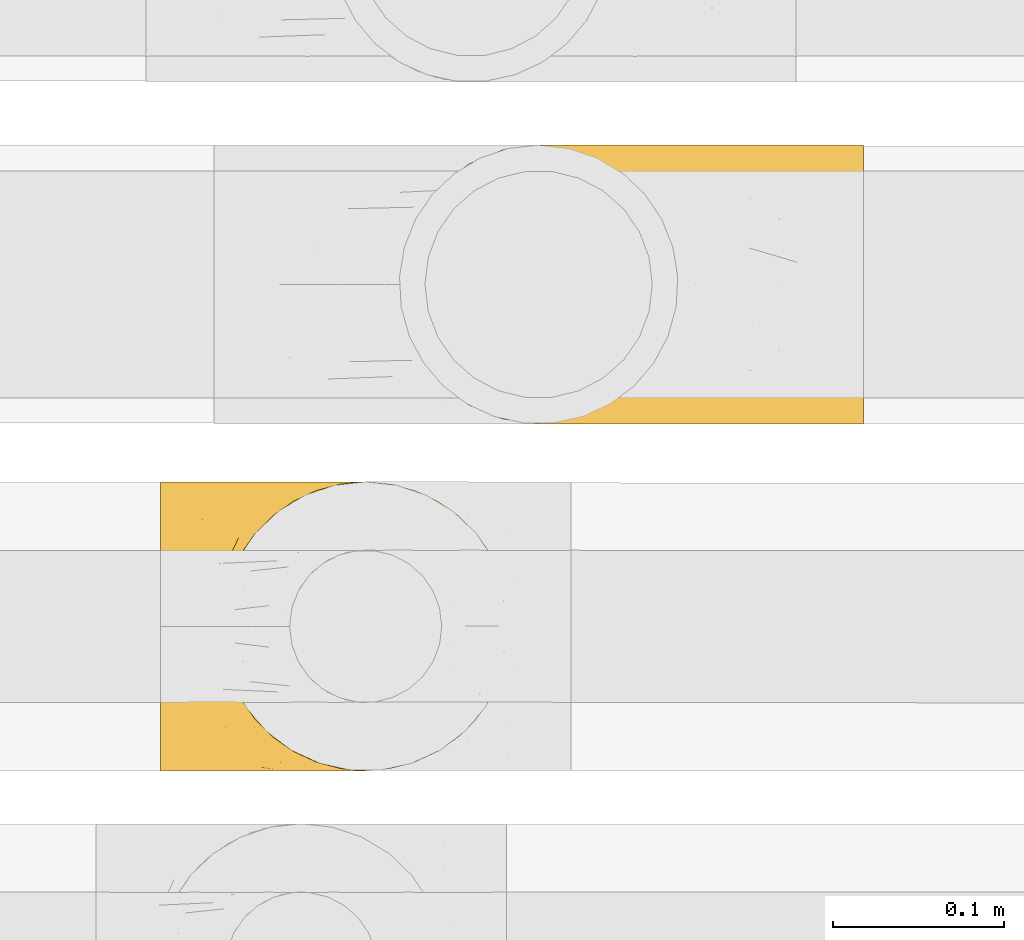
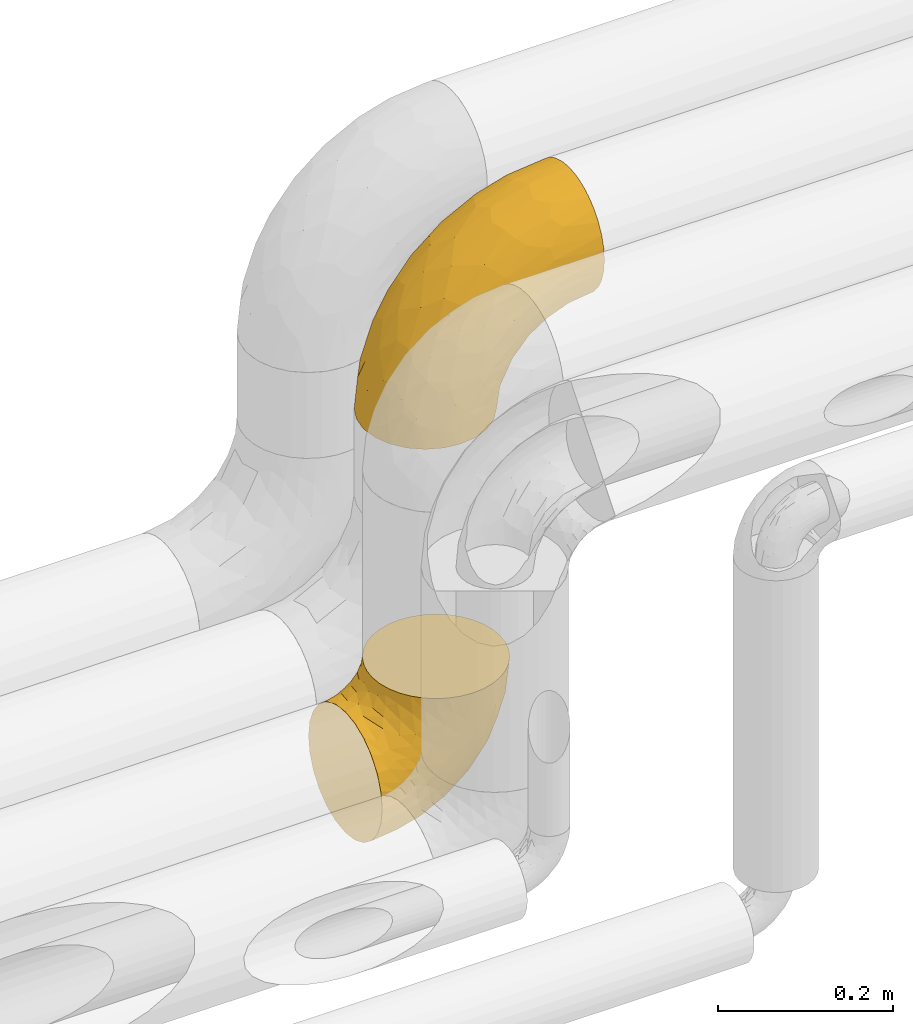
# One storey, part 15 of 93: 2 coverings.
"""IFC2X3 building model written with IfcOpenShell, lengths in millimetres."""

from ifc_helpers import new_model, entity, si_unit, converted_unit, derived_unit, direction, frame, origin, place, context, subcontext, project, spatial, faceted_brep, element, save


model = new_model("IFC2X3")

# Units and contexts
model_context = context("Model", 3, precision=0.01, world=origin(), true_north=direction((6.12303176911189e-17, 1.0)))
body_context = subcontext(model_context, "Body", "Model", "MODEL_VIEW")
ifc_project = project(units=[si_unit("LENGTHUNIT", "METRE", prefix="MILLI"), si_unit("AREAUNIT", "SQUARE_METRE"), si_unit("VOLUMEUNIT", "CUBIC_METRE"), converted_unit("PLANEANGLEUNIT", "DEGREE", entity("IfcRatioMeasure", 0.0174532925199433), si_unit("PLANEANGLEUNIT", "RADIAN"), dimensions=[0, 0, 0, 0, 0, 0, 0]), si_unit("MASSUNIT", "GRAM", prefix="KILO"), derived_unit("MASSDENSITYUNIT", [(si_unit("MASSUNIT", "GRAM", prefix="KILO"), 1), (si_unit("LENGTHUNIT", "METRE"), -3)]), derived_unit("MOMENTOFINERTIAUNIT", [(si_unit("LENGTHUNIT", "METRE"), 4)]), si_unit("TIMEUNIT", "SECOND"), si_unit("FREQUENCYUNIT", "HERTZ"), si_unit("THERMODYNAMICTEMPERATUREUNIT", "DEGREE_CELSIUS"), derived_unit("THERMALTRANSMITTANCEUNIT", [(si_unit("MASSUNIT", "GRAM", prefix="KILO"), 1), (si_unit("THERMODYNAMICTEMPERATUREUNIT", "KELVIN"), -1), (si_unit("TIMEUNIT", "SECOND"), -3)]), derived_unit("VOLUMETRICFLOWRATEUNIT", [(si_unit("LENGTHUNIT", "METRE"), 3), (si_unit("TIMEUNIT", "SECOND"), -1)]), derived_unit("MASSFLOWRATEUNIT", [(si_unit("MASSUNIT", "GRAM", prefix="KILO"), 1), (si_unit("TIMEUNIT", "SECOND"), -1)]), derived_unit("ROTATIONALFREQUENCYUNIT", [(si_unit("TIMEUNIT", "SECOND"), -1)]), si_unit("ELECTRICCURRENTUNIT", "AMPERE"), si_unit("ELECTRICVOLTAGEUNIT", "VOLT"), si_unit("POWERUNIT", "WATT"), si_unit("FORCEUNIT", "NEWTON", prefix="KILO"), si_unit("ILLUMINANCEUNIT", "LUX"), si_unit("LUMINOUSFLUXUNIT", "LUMEN"), si_unit("LUMINOUSINTENSITYUNIT", "CANDELA"), derived_unit("USERDEFINED", [(si_unit("MASSUNIT", "GRAM", prefix="KILO"), -1), (si_unit("LENGTHUNIT", "METRE"), -2), (si_unit("TIMEUNIT", "SECOND"), 3), (si_unit("LUMINOUSFLUXUNIT", "LUMEN"), 1)]), derived_unit("LINEARVELOCITYUNIT", [(si_unit("LENGTHUNIT", "METRE"), 1), (si_unit("TIMEUNIT", "SECOND"), -1)]), si_unit("PRESSUREUNIT", "PASCAL"), derived_unit("USERDEFINED", [(si_unit("LENGTHUNIT", "METRE"), -2), (si_unit("MASSUNIT", "GRAM", prefix="KILO"), 1), (si_unit("TIMEUNIT", "SECOND"), -2)]), derived_unit("LINEARFORCEUNIT", [(si_unit("MASSUNIT", "GRAM", prefix="KILO"), 1), (si_unit("LENGTHUNIT", "METRE"), 1), (si_unit("TIMEUNIT", "SECOND"), -2), (si_unit("LENGTHUNIT", "METRE"), -1)]), derived_unit("PLANARFORCEUNIT", [(si_unit("MASSUNIT", "GRAM", prefix="KILO"), 1), (si_unit("LENGTHUNIT", "METRE"), 1), (si_unit("TIMEUNIT", "SECOND"), -2), (si_unit("LENGTHUNIT", "METRE"), -2)])], contexts=[model_context])

# Site, building, storey
site_placement = place(None, origin())
site = spatial("IfcSite", under=ifc_project, at=site_placement, CompositionType="ELEMENT")
building_placement = place(site_placement, origin())
building = spatial("IfcBuilding", under=site, at=building_placement, CompositionType="ELEMENT")
storey_placement = place(building_placement, frame((0.0, 0.0, -4200.0)))
storey = spatial("IfcBuildingStorey", under=building, at=storey_placement, CompositionType="ELEMENT", Elevation=-4200.0)

# Coverings
covering_1_placement = place(storey_placement, frame((-1935.28, 14216.91, 2808.4)))
element("IfcCovering", 1, at=covering_1_placement, inside=storey, Name=":ADSK_", ObjectType=":ADSK_", PredefinedType="INSULATION", context=body_context, shape_type="Brep", body=[
    faceted_brep([(273.1, 158.39, 222.78), (273.1, 150.86, 236.87), (273.1, 140.72, 249.22), (273.1, 128.37, 259.36), (273.1, 114.28, 266.89), (273.1, 98.99, 271.53), (273.1, 83.1, 273.1), (273.1, 67.2, 271.53), (273.1, 51.91, 266.89), (273.1, 37.82, 259.36), (273.1, 25.47, 249.22), (273.1, 15.33, 236.87), (273.1, 7.8, 222.78), (273.1, 3.16, 207.49), (273.1, 1.6, 191.6), (273.1, 3.16, 175.7), (273.1, 7.8, 160.41), (273.1, 15.33, 146.32), (273.1, 25.47, 133.97), (273.1, 37.82, 123.83), (273.1, 51.91, 116.3), (273.1, 67.2, 111.66), (273.1, 83.1, 110.1), (273.1, 99.0, 111.66), (273.1, 114.28, 116.3), (273.1, 128.37, 123.83), (273.1, 140.72, 133.97), (273.1, 150.86, 146.32), (273.1, 158.39, 160.41), (273.1, 163.03, 175.7), (273.1, 164.6, 191.6), (273.1, 163.03, 207.5), (161.82, 62.0, 1.6), (153.68, 42.35, 1.6), (140.72, 25.47, 1.6), (123.85, 12.51, 1.6), (104.19, 4.37, 1.6), (83.1, 1.6, 1.6), (62.0, 4.37, 1.6), (42.35, 12.51, 1.6), (25.47, 25.47, 1.6), (12.51, 42.35, 1.6), (4.37, 62.0, 1.6), (1.6, 83.1, 1.6), (4.37, 104.19, 1.6), (12.51, 123.85, 1.6), (25.47, 140.72, 1.6), (42.35, 153.68, 1.6), (62.0, 161.82, 1.6), (83.1, 164.6, 1.6), (104.19, 161.82, 1.6), (123.85, 153.68, 1.6), (140.72, 140.72, 1.6), (153.68, 123.85, 1.6), (161.82, 104.19, 1.6), (164.6, 83.1, 1.6), (15.45, 104.67, 77.51), (6.81, 83.1, 54.56), (22.26, 83.1, 105.49), (42.42, 132.71, 109.47), (71.44, 128.57, 161.95), (65.97, 140.31, 138.06), (113.44, 127.0, 205.1), (65.75, 111.93, 168.59), (103.59, 107.33, 208.94), (63.94, 96.47, 172.96), (218.6, 153.13, 226.77), (39.77, 119.3, 122.99), (36.91, 101.32, 131.27), (138.84, 142.92, 206.95), (183.71, 142.61, 230.44), (168.19, 151.87, 210.46), (71.48, 162.56, 53.16), (101.91, 164.6, 84.03), (87.86, 164.6, 43.87), (47.35, 83.1, 152.43), (167.63, 117.97, 243.25), (212.84, 119.64, 257.44), (173.72, 131.15, 237.33), (81.12, 83.1, 193.57), (122.26, 83.1, 227.34), (56.45, 156.52, 63.71), (46.95, 144.21, 92.99), (35.05, 146.25, 42.41), (24.32, 130.43, 63.41), (230.82, 164.6, 186.83), (195.92, 162.51, 195.08), (92.81, 159.97, 122.49), (82.34, 151.26, 138.28), (122.78, 151.21, 181.92), (13.53, 117.68, 48.64), (149.02, 158.25, 185.11), (154.38, 163.04, 169.75), (212.27, 105.24, 263.05), (160.47, 100.78, 246.5), (230.92, 144.52, 241.49), (98.82, 141.87, 175.87), (218.75, 132.77, 250.34), (169.2, 83.1, 252.43), (220.13, 83.1, 267.88), (190.66, 164.6, 172.78), (154.63, 164.6, 150.14), (124.55, 164.6, 120.06), (131.16, 151.23, 32.61), (150.42, 137.69, 43.04), (110.62, 161.34, 41.06), (211.28, 141.27, 119.26), (240.6, 138.72, 127.92), (223.71, 127.05, 112.47), (203.39, 109.71, 90.5), (239.57, 83.1, 104.78), (209.32, 83.1, 89.37), (171.53, 120.43, 60.79), (166.55, 138.75, 76.89), (191.93, 129.2, 93.74), (173.04, 161.91, 138.12), (198.01, 161.43, 151.34), (187.52, 155.97, 129.05), (125.16, 162.57, 89.24), (157.77, 160.03, 116.92), (158.24, 151.82, 92.03), (160.57, 117.14, 29.57), (242.02, 109.48, 110.12), (248.61, 148.92, 141.41), (220.59, 151.93, 138.22), (137.18, 154.85, 68.2), (165.92, 98.92, 26.59), (175.12, 100.98, 52.67), (185.32, 83.1, 65.37), (169.91, 83.1, 35.12), (184.45, 145.5, 106.81), (238.32, 158.16, 155.99), (217.41, 162.97, 166.25), (245.77, 162.71, 171.98), (190.73, 98.76, 74.54), (121.56, 160.15, 62.85), (249.77, 124.12, 118.88), (171.52, 154.06, 111.86), (137.18, 11.34, 68.2), (150.42, 28.5, 43.04), (166.55, 27.44, 76.89), (158.24, 14.37, 92.03), (165.92, 67.27, 26.59), (175.12, 65.22, 52.67), (223.71, 39.14, 112.47), (211.28, 24.93, 119.26), (191.92, 36.99, 93.74), (245.77, 3.48, 171.98), (203.4, 56.48, 90.5), (131.16, 14.96, 32.61), (110.62, 4.85, 41.06), (249.77, 42.07, 118.88), (240.6, 27.47, 127.91), (171.53, 45.76, 60.79), (190.73, 67.43, 74.54), (217.41, 3.22, 166.25), (238.31, 8.03, 155.99), (87.86, 1.6, 43.87), (160.57, 49.05, 29.57), (248.61, 17.27, 141.41), (242.02, 56.71, 110.12), (111.86, 3.08, 68.35), (125.16, 3.62, 89.24), (190.66, 1.6, 172.78), (154.63, 1.6, 150.14), (198.01, 4.76, 151.34), (124.55, 1.6, 120.06), (101.91, 1.6, 84.03), (184.45, 20.69, 106.81), (157.77, 6.16, 116.92), (220.59, 14.26, 138.22), (187.52, 10.22, 129.05), (173.04, 4.28, 138.12), (230.82, 1.6, 186.83), (171.95, 12.35, 111.73), (24.32, 35.76, 63.41), (183.71, 23.58, 230.44), (173.75, 35.03, 237.34), (133.19, 34.03, 214.88), (229.24, 46.35, 260.65), (79.61, 3.68, 78.77), (104.94, 3.15, 120.31), (89.58, 7.94, 125.68), (98.82, 24.32, 175.87), (84.08, 41.48, 180.24), (152.2, 6.22, 181.88), (198.75, 2.91, 192.21), (62.55, 57.48, 166.39), (58.85, 10.43, 76.36), (40.65, 33.0, 104.7), (46.95, 21.98, 92.99), (63.87, 28.1, 138.7), (22.06, 47.91, 81.73), (230.92, 21.67, 241.49), (103.59, 58.86, 208.94), (207.65, 13.93, 225.32), (39.77, 46.89, 122.99), (34.68, 62.93, 126.09), (35.05, 19.94, 42.41), (15.45, 61.52, 77.51), (150.41, 15.08, 201.91), (210.73, 6.68, 210.82), (160.46, 65.41, 246.49), (79.42, 16.65, 138.52), (115.1, 11.53, 167.35), (212.26, 60.95, 263.05), (218.75, 33.42, 250.34), (167.63, 48.22, 243.25)], [[[0, 1, 2, 3, 4, 5, 6, 7, 8, 9, 10, 11, 12, 13, 14, 15, 16, 17, 18, 19, 20, 21, 22, 23, 24, 25, 26, 27, 28, 29, 30, 31]], [[32, 33, 34, 35, 36, 37, 38, 39, 40, 41, 42, 43, 44, 45, 46, 47, 48, 49, 50, 51, 52, 53, 54, 55]], [[56, 57, 58]], [[57, 44, 43]], [[59, 60, 61]], [[62, 63, 64]], [[63, 65, 64]], [[1, 0, 66]], [[67, 68, 63]], [[69, 70, 71]], [[72, 73, 74]], [[75, 68, 58]], [[76, 77, 78]], [[64, 79, 80]], [[81, 48, 47]], [[82, 83, 84]], [[31, 85, 86]], [[71, 70, 66]], [[47, 83, 81]], [[87, 88, 89]], [[69, 62, 78]], [[49, 48, 72]], [[90, 44, 56]], [[48, 81, 72]], [[87, 91, 92]], [[93, 76, 94]], [[70, 95, 66]], [[88, 96, 89]], [[45, 84, 46]], [[2, 95, 97]], [[4, 93, 5]], [[98, 99, 93]], [[59, 84, 67]], [[3, 97, 77]], [[71, 86, 91]], [[4, 3, 77]], [[90, 84, 45]], [[99, 6, 5]], [[83, 47, 46]], [[95, 2, 1]], [[94, 80, 98]], [[100, 101, 92]], [[66, 31, 86]], [[60, 63, 62]], [[85, 31, 30]], [[102, 87, 92]], [[93, 77, 76]], [[91, 86, 92]], [[44, 57, 56]], [[86, 85, 100]], [[78, 97, 70]], [[87, 102, 73]], [[2, 97, 3]], [[67, 84, 90]], [[31, 66, 0]], [[93, 94, 98]], [[88, 81, 82]], [[99, 5, 93]], [[87, 73, 72]], [[66, 95, 1]], [[97, 95, 70]], [[86, 71, 66]], [[69, 89, 96]], [[89, 71, 91]], [[69, 96, 62]], [[60, 62, 96]], [[76, 62, 64]], [[71, 89, 69]], [[87, 89, 91]], [[81, 88, 87]], [[61, 88, 82]], [[61, 60, 96]], [[60, 67, 63]], [[68, 67, 56]], [[79, 65, 75]], [[58, 68, 56]], [[65, 68, 75]], [[64, 65, 79]], [[68, 65, 63]], [[76, 64, 94]], [[80, 94, 64]], [[100, 92, 86]], [[92, 101, 102]], [[88, 61, 96]], [[59, 61, 82]], [[84, 59, 82]], [[60, 59, 67]], [[87, 72, 81]], [[49, 72, 74]], [[84, 83, 46]], [[81, 83, 82]], [[69, 78, 70]], [[62, 76, 78]], [[4, 77, 93]], [[78, 77, 97]], [[44, 90, 45]], [[67, 90, 56]], [[103, 104, 52]], [[50, 49, 74]], [[50, 74, 105]], [[106, 107, 108]], [[109, 110, 111]], [[112, 113, 114]], [[104, 113, 112]], [[73, 105, 74]], [[115, 116, 117]], [[118, 119, 120]], [[104, 53, 52]], [[51, 103, 52]], [[53, 121, 54]], [[24, 23, 122]], [[123, 107, 124]], [[122, 109, 108]], [[125, 120, 113]], [[55, 54, 126]], [[102, 118, 73]], [[127, 126, 121]], [[128, 129, 127]], [[105, 51, 50]], [[102, 101, 119]], [[120, 130, 113]], [[26, 123, 27]], [[27, 131, 28]], [[132, 85, 133]], [[85, 29, 133]], [[134, 111, 128]], [[28, 133, 29]], [[30, 29, 85]], [[116, 131, 124]], [[135, 73, 118]], [[27, 123, 131]], [[110, 23, 22]], [[136, 122, 108]], [[24, 136, 25]], [[114, 108, 109]], [[119, 115, 117]], [[136, 107, 25]], [[128, 127, 134]], [[122, 110, 109]], [[104, 112, 121]], [[107, 106, 124]], [[107, 26, 25]], [[23, 110, 122]], [[101, 100, 116]], [[131, 132, 133]], [[105, 135, 103]], [[116, 124, 117]], [[122, 136, 24]], [[107, 136, 108]], [[28, 131, 133]], [[131, 116, 132]], [[126, 127, 129]], [[134, 112, 109]], [[107, 123, 26]], [[131, 123, 124]], [[104, 121, 53]], [[127, 121, 112]], [[105, 103, 51]], [[104, 103, 125]], [[116, 100, 132]], [[85, 132, 100]], [[106, 117, 124]], [[137, 130, 120]], [[114, 106, 108]], [[106, 130, 117]], [[119, 118, 102]], [[135, 118, 125]], [[125, 113, 104]], [[114, 113, 130]], [[114, 130, 106]], [[112, 114, 109]], [[118, 120, 125]], [[117, 137, 119]], [[55, 126, 129]], [[121, 126, 54]], [[112, 134, 127]], [[111, 134, 109]], [[119, 101, 115]], [[101, 116, 115]], [[103, 135, 125]], [[73, 135, 105]], [[130, 137, 117]], [[120, 119, 137]], [[138, 139, 140]], [[140, 141, 138]], [[55, 129, 142]], [[143, 142, 129]], [[144, 145, 146]], [[147, 16, 15]], [[110, 148, 111]], [[128, 143, 129]], [[149, 150, 35]], [[151, 152, 144]], [[153, 143, 154]], [[147, 155, 156]], [[35, 150, 36]], [[37, 36, 157]], [[35, 34, 149]], [[139, 33, 158]], [[159, 152, 18]], [[150, 157, 36]], [[140, 139, 153]], [[139, 34, 33]], [[110, 21, 160]], [[150, 161, 157]], [[20, 19, 151]], [[161, 138, 162]], [[110, 22, 21]], [[163, 164, 165]], [[166, 167, 162]], [[151, 160, 20]], [[140, 146, 168]], [[111, 148, 154]], [[164, 166, 169]], [[18, 152, 19]], [[170, 156, 165]], [[17, 159, 18]], [[158, 33, 32]], [[171, 165, 172]], [[155, 165, 156]], [[148, 110, 160]], [[170, 159, 156]], [[160, 144, 148]], [[15, 14, 173]], [[170, 171, 145]], [[149, 139, 138]], [[15, 173, 147]], [[144, 152, 145]], [[156, 17, 16]], [[165, 171, 170]], [[20, 160, 21]], [[171, 172, 169]], [[169, 166, 162]], [[152, 151, 19]], [[160, 151, 144]], [[155, 173, 163]], [[156, 16, 147]], [[154, 143, 128]], [[143, 153, 158]], [[156, 159, 17]], [[152, 159, 170]], [[158, 32, 142]], [[139, 158, 153]], [[139, 149, 34]], [[150, 149, 138]], [[173, 155, 147]], [[163, 165, 155]], [[174, 169, 141]], [[145, 171, 168]], [[170, 145, 152]], [[146, 145, 168]], [[161, 162, 167]], [[162, 138, 141]], [[146, 153, 148]], [[140, 168, 141]], [[153, 146, 140]], [[144, 146, 148]], [[174, 141, 168]], [[162, 141, 169]], [[158, 142, 143]], [[55, 142, 32]], [[111, 154, 128]], [[153, 154, 148]], [[165, 164, 172]], [[164, 169, 172]], [[157, 161, 167]], [[138, 161, 150]], [[168, 171, 174]], [[169, 174, 171]], [[41, 40, 175]], [[176, 177, 178]], [[9, 8, 179]], [[180, 181, 182]], [[157, 180, 37]], [[183, 178, 184]], [[164, 185, 181]], [[13, 186, 173]], [[187, 79, 75]], [[167, 166, 181]], [[186, 163, 173]], [[182, 188, 180]], [[57, 43, 42]], [[189, 190, 191]], [[164, 186, 185]], [[192, 41, 175]], [[193, 11, 10]], [[178, 194, 184]], [[12, 11, 195]], [[196, 187, 197]], [[40, 198, 175]], [[198, 40, 39]], [[58, 199, 197]], [[200, 185, 201]], [[163, 186, 164]], [[201, 185, 186]], [[202, 80, 194]], [[190, 203, 191]], [[201, 186, 13]], [[204, 185, 200]], [[201, 13, 12]], [[41, 199, 42]], [[195, 200, 201]], [[98, 205, 99]], [[57, 42, 199]], [[13, 173, 14]], [[58, 57, 199]], [[193, 206, 176]], [[80, 79, 194]], [[207, 205, 202]], [[196, 184, 187]], [[202, 205, 98]], [[205, 179, 8]], [[9, 206, 10]], [[207, 206, 179]], [[182, 203, 188]], [[6, 99, 7]], [[188, 38, 180]], [[203, 182, 204]], [[7, 205, 8]], [[37, 180, 38]], [[167, 180, 157]], [[7, 99, 205]], [[182, 181, 185]], [[11, 193, 195]], [[196, 191, 184]], [[175, 189, 192]], [[198, 188, 190]], [[38, 188, 39]], [[206, 193, 10]], [[195, 193, 176]], [[195, 176, 200]], [[12, 195, 201]], [[178, 200, 176]], [[185, 204, 182]], [[200, 183, 204]], [[203, 204, 183]], [[191, 203, 183]], [[188, 203, 190]], [[184, 191, 183]], [[190, 189, 175]], [[200, 178, 183]], [[184, 194, 187]], [[177, 176, 206]], [[194, 178, 207]], [[79, 187, 194]], [[197, 199, 192]], [[187, 75, 197]], [[58, 197, 75]], [[191, 196, 189]], [[192, 189, 196]], [[80, 202, 98]], [[194, 207, 202]], [[167, 181, 180]], [[181, 166, 164]], [[188, 198, 39]], [[175, 198, 190]], [[207, 179, 205]], [[9, 179, 206]], [[197, 192, 196]], [[41, 192, 199]], [[206, 207, 177]], [[207, 178, 177]]]),
])
covering_2_placement = place(storey_placement, frame((-2074.95, 14013.91, 2414.21)))
element("IfcCovering", 2, at=covering_2_placement, inside=storey, Name=":ADSK_", ObjectType=":ADSK_", PredefinedType="INSULATION", context=body_context, shape_type="Brep", body=[
    faceted_brep([(150.5, 6.69, 206.1), (163.85, 12.92, 206.1), (175.91, 21.37, 206.1), (186.33, 31.78, 206.1), (194.77, 43.85, 206.1), (201.0, 57.19, 206.1), (204.81, 71.42, 206.1), (206.1, 86.1, 206.1), (204.81, 100.77, 206.1), (201.0, 115.0, 206.1), (194.77, 128.35, 206.1), (186.32, 140.41, 206.1), (175.91, 150.83, 206.1), (163.84, 159.27, 206.1), (150.5, 165.5, 206.1), (136.27, 169.31, 206.1), (121.6, 170.6, 206.1), (106.92, 169.31, 206.1), (92.69, 165.5, 206.1), (79.34, 159.27, 206.1), (67.28, 150.82, 206.1), (56.86, 140.41, 206.1), (48.42, 128.34, 206.1), (42.19, 115.0, 206.1), (38.38, 100.77, 206.1), (37.1, 86.1, 206.1), (38.38, 71.42, 206.1), (42.19, 57.19, 206.1), (48.42, 43.84, 206.1), (56.87, 31.78, 206.1), (67.28, 21.36, 206.1), (79.35, 12.92, 206.1), (92.69, 6.69, 206.1), (99.81, 4.79, 206.1), (106.92, 2.88, 206.1), (121.6, 1.6, 206.1), (136.27, 2.88, 206.1), (1.6, 86.1, 170.6), (1.6, 107.97, 167.72), (1.6, 128.35, 159.27), (1.6, 145.85, 145.85), (1.6, 159.27, 128.35), (1.6, 167.72, 107.97), (1.6, 168.82, 99.56), (1.6, 170.6, 86.1), (1.6, 167.72, 64.23), (1.6, 159.27, 43.85), (1.6, 145.85, 26.34), (1.6, 128.35, 12.92), (1.6, 107.97, 4.47), (1.6, 86.1, 1.6), (1.6, 64.23, 4.47), (1.6, 43.85, 12.92), (1.6, 26.34, 26.34), (1.6, 12.92, 43.85), (1.6, 4.47, 64.23), (1.6, 1.6, 86.1), (1.6, 3.37, 99.56), (1.6, 4.47, 107.97), (1.6, 8.7, 118.16), (1.6, 12.92, 128.35), (1.6, 26.34, 145.85), (1.6, 43.85, 159.27), (1.6, 64.23, 167.72), (47.1, 86.1, 6.72), (90.32, 86.1, 21.85), (76.74, 70.39, 17.49), (45.07, 70.66, 7.72), (54.43, 56.88, 13.94), (130.85, 28.12, 78.7), (102.9, 18.64, 68.47), (101.57, 31.21, 51.33), (129.1, 86.1, 46.21), (109.1, 70.41, 33.86), (42.18, 10.43, 53.79), (157.11, 29.48, 110.17), (165.26, 21.45, 145.81), (145.37, 16.68, 118.82), (180.34, 29.1, 169.84), (144.69, 67.25, 63.0), (161.48, 86.1, 78.59), (172.76, 63.85, 99.74), (29.38, 21.08, 34.35), (42.46, 37.65, 21.32), (194.48, 53.11, 162.31), (193.55, 69.85, 140.29), (201.3, 66.89, 173.87), (46.37, 4.01, 73.41), (101.41, 4.29, 106.28), (98.68, 1.6, 135.56), (85.4, 1.6, 122.29), (72.13, 1.6, 109.01), (137.0, 8.08, 136.01), (119.7, 12.22, 96.64), (119.97, 3.07, 139.72), (115.72, 1.6, 169.01), (107.2, 1.6, 152.29), (76.04, 4.22, 86.47), (55.4, 1.6, 100.49), (38.68, 1.6, 91.97), (185.84, 86.1, 117.37), (177.95, 43.5, 127.74), (157.62, 11.81, 169.45), (65.3, 23.97, 40.66), (82.09, 9.27, 73.41), (149.99, 46.38, 80.23), (200.97, 86.1, 160.59), (136.93, 4.15, 167.92), (119.25, 1.6, 191.28), (117.49, 1.6, 180.15), (104.96, 52.19, 37.92), (75.57, 36.38, 32.9), (27.54, 1.6, 90.21), (16.41, 1.6, 88.44), (48.91, 15.12, 149.02), (55.45, 17.96, 161.35), (39.69, 27.16, 160.46), (35.54, 7.89, 124.9), (48.76, 3.04, 112.91), (52.0, 5.06, 124.31), (27.71, 4.56, 111.82), (19.57, 3.21, 104.11), (26.99, 15.37, 136.85), (16.3, 12.85, 129.63), (56.69, 27.24, 183.96), (44.9, 34.03, 174.77), (14.18, 23.54, 144.17), (32.34, 86.1, 188.35), (26.88, 67.27, 178.24), (35.03, 70.89, 190.53), (12.19, 48.67, 163.14), (46.38, 43.58, 191.92), (14.56, 68.19, 170.99), (31.42, 50.33, 174.51), (25.84, 42.35, 165.01), (80.65, 11.32, 190.2), (67.99, 19.09, 189.17), (86.7, 6.4, 171.39), (105.36, 2.96, 190.71), (37.11, 55.59, 185.21), (82.94, 5.24, 156.15), (69.47, 13.15, 168.99), (71.96, 6.52, 147.47), (96.9, 4.62, 185.14), (39.9, 60.15, 196.12), (14.17, 35.8, 155.54), (58.72, 6.76, 135.37), (40.86, 12.09, 137.28), (66.83, 2.76, 122.5), (19.35, 86.1, 175.35), (24.13, 24.23, 147.86), (26.89, 104.92, 178.24), (64.55, 168.84, 124.75), (58.43, 163.83, 140.4), (74.15, 168.6, 134.79), (35.03, 101.29, 190.53), (32.21, 142.93, 157.46), (40.64, 140.34, 167.05), (45.95, 153.44, 153.29), (14.56, 104.01, 170.99), (46.39, 128.36, 192.44), (56.57, 144.2, 185.67), (47.33, 163.94, 131.94), (12.22, 144.45, 148.18), (25.77, 148.65, 147.71), (20.39, 155.16, 137.3), (47.38, 138.15, 178.55), (18.5, 168.5, 106.23), (18.72, 161.91, 125.2), (32.32, 168.4, 110.01), (35.54, 164.3, 124.9), (53.79, 169.08, 116.08), (104.3, 169.14, 187.44), (37.11, 116.59, 185.21), (72.13, 170.6, 109.01), (39.9, 112.04, 196.13), (56.59, 153.76, 163.78), (119.25, 170.6, 191.28), (117.49, 170.6, 180.15), (27.54, 170.6, 90.21), (16.41, 170.6, 88.44), (67.82, 152.86, 189.79), (83.63, 163.25, 181.87), (20.61, 127.4, 163.9), (92.44, 168.42, 162.06), (100.06, 169.02, 173.37), (71.69, 160.2, 168.81), (84.22, 169.11, 142.59), (85.4, 170.6, 122.29), (115.72, 170.6, 169.01), (31.34, 123.79, 173.17), (70.29, 164.38, 150.79), (107.2, 170.6, 152.29), (98.68, 170.6, 135.56), (38.68, 170.6, 91.97), (55.4, 170.6, 100.49), (101.41, 167.9, 106.28), (72.18, 169.24, 90.96), (145.37, 155.51, 118.83), (157.62, 160.38, 169.45), (165.25, 150.75, 145.81), (109.1, 101.78, 33.86), (76.74, 101.8, 17.49), (104.96, 120.0, 37.92), (46.36, 168.19, 73.4), (82.09, 162.92, 73.41), (119.7, 159.97, 96.64), (42.18, 161.76, 53.79), (157.11, 142.72, 110.16), (130.84, 144.07, 78.7), (45.07, 101.53, 7.72), (136.93, 168.04, 167.93), (172.76, 108.34, 99.74), (144.69, 104.94, 63.0), (149.99, 125.82, 80.23), (54.43, 115.31, 13.94), (177.94, 128.7, 127.74), (29.38, 151.11, 34.35), (65.31, 148.22, 40.66), (75.58, 135.81, 32.91), (42.46, 134.54, 21.32), (180.33, 143.1, 169.84), (119.97, 169.12, 139.72), (137.0, 164.11, 136.02), (102.89, 153.55, 68.47), (101.56, 140.99, 51.33), (194.48, 119.09, 162.31), (193.55, 102.34, 140.29), (201.3, 105.31, 173.87)], [[[0, 1, 2, 3, 4, 5, 6, 7, 8, 9, 10, 11, 12, 13, 14, 15, 16, 17, 18, 19, 20, 21, 22, 23, 24, 25, 26, 27, 28, 29, 30, 31, 32, 33, 34, 35, 36]], [[37, 38, 39, 40, 41, 42, 43, 44, 45, 46, 47, 48, 49, 50, 51, 52, 53, 54, 55, 56, 57, 58, 59, 60, 61, 62, 63]], [[64, 65, 66]], [[67, 50, 64]], [[68, 52, 51]], [[69, 70, 71]], [[72, 73, 65]], [[54, 74, 55]], [[75, 76, 77]], [[65, 73, 66]], [[2, 78, 3]], [[79, 80, 81]], [[53, 82, 54]], [[53, 52, 83]], [[52, 68, 83]], [[84, 85, 86]], [[74, 87, 55]], [[88, 89, 90, 91]], [[92, 93, 77]], [[56, 55, 87]], [[94, 95, 96, 89]], [[92, 88, 93]], [[97, 91, 98, 99]], [[93, 70, 69]], [[81, 80, 100]], [[101, 81, 85]], [[76, 1, 102]], [[74, 103, 104]], [[5, 4, 84]], [[84, 4, 78]], [[80, 79, 72]], [[84, 86, 5]], [[77, 102, 92]], [[3, 78, 4]], [[101, 75, 105]], [[106, 7, 6]], [[100, 106, 85]], [[76, 78, 2]], [[107, 35, 108, 109, 95]], [[107, 95, 94]], [[94, 88, 92]], [[79, 105, 110]], [[71, 103, 111]], [[0, 107, 102]], [[84, 78, 101]], [[97, 99, 87]], [[66, 67, 64]], [[1, 76, 2]], [[0, 102, 1]], [[76, 101, 78]], [[107, 0, 36]], [[81, 100, 85]], [[88, 94, 89]], [[93, 88, 104]], [[107, 94, 92]], [[105, 79, 81]], [[73, 79, 110]], [[101, 105, 81]], [[105, 69, 71]], [[111, 68, 110]], [[82, 83, 103]], [[102, 107, 92]], [[107, 36, 35]], [[74, 54, 82]], [[87, 74, 104]], [[97, 87, 104]], [[87, 99, 112, 113, 56]], [[70, 93, 104]], [[77, 76, 102]], [[86, 106, 6]], [[85, 84, 101]], [[79, 73, 72]], [[66, 110, 68]], [[110, 66, 73]], [[66, 68, 67]], [[68, 51, 67]], [[50, 67, 51]], [[104, 103, 70]], [[71, 70, 103]], [[111, 103, 83]], [[105, 71, 110]], [[68, 111, 83]], [[110, 71, 111]], [[93, 69, 77]], [[75, 77, 69]], [[105, 75, 69]], [[101, 76, 75]], [[106, 86, 85]], [[5, 86, 6]], [[83, 82, 53]], [[74, 82, 103]], [[104, 88, 97]], [[91, 97, 88]], [[114, 115, 116]], [[113, 112, 58, 57, 56]], [[117, 118, 119]], [[120, 121, 99]], [[120, 99, 98]], [[117, 122, 123]], [[124, 125, 115]], [[62, 61, 126]], [[127, 128, 129]], [[115, 125, 116]], [[130, 63, 62]], [[28, 131, 124]], [[132, 37, 63]], [[133, 132, 134]], [[135, 136, 137]], [[138, 108, 34]], [[128, 139, 129]], [[89, 96, 140]], [[140, 141, 142]], [[32, 31, 143]], [[34, 33, 32, 138]], [[29, 124, 136]], [[141, 124, 115]], [[135, 31, 30]], [[116, 125, 133]], [[35, 34, 108]], [[28, 27, 131]], [[124, 141, 136]], [[144, 131, 27]], [[127, 129, 25]], [[139, 144, 129]], [[95, 109, 108, 138]], [[134, 130, 145]], [[28, 124, 29]], [[29, 136, 30]], [[121, 120, 59]], [[27, 26, 144]], [[124, 131, 125]], [[146, 114, 147]], [[115, 114, 142]], [[131, 139, 125]], [[117, 147, 122]], [[125, 139, 133]], [[135, 143, 31]], [[143, 137, 96]], [[142, 90, 89]], [[137, 136, 141]], [[146, 119, 148]], [[115, 142, 141]], [[119, 146, 147]], [[142, 146, 148]], [[141, 140, 137]], [[26, 25, 129]], [[131, 144, 139]], [[136, 135, 30]], [[143, 135, 137]], [[26, 129, 144]], [[128, 127, 149]], [[132, 128, 149]], [[133, 139, 128]], [[37, 132, 149]], [[132, 63, 130]], [[134, 150, 116]], [[119, 147, 117]], [[150, 114, 116]], [[142, 114, 146]], [[114, 150, 147]], [[122, 147, 150]], [[98, 118, 120]], [[148, 119, 91]], [[118, 117, 120]], [[119, 118, 91]], [[91, 118, 98]], [[123, 120, 117]], [[58, 112, 121]], [[91, 90, 148]], [[142, 148, 90]], [[132, 133, 128]], [[133, 134, 116]], [[142, 89, 140]], [[95, 143, 96]], [[150, 126, 122]], [[123, 61, 60]], [[123, 122, 126]], [[120, 123, 60]], [[126, 150, 145]], [[123, 126, 61]], [[140, 96, 137]], [[145, 130, 62]], [[132, 130, 134]], [[126, 145, 62]], [[134, 145, 150]], [[32, 143, 138]], [[95, 138, 143]], [[121, 112, 99]], [[120, 60, 59]], [[58, 121, 59]], [[149, 127, 151]], [[152, 153, 154]], [[127, 155, 151]], [[156, 157, 158]], [[159, 149, 151]], [[159, 37, 149]], [[160, 22, 161]], [[153, 152, 162]], [[163, 164, 165]], [[166, 160, 161]], [[167, 41, 168]], [[169, 170, 171]], [[169, 168, 170]], [[168, 165, 170]], [[172, 19, 18]], [[166, 173, 160]], [[174, 171, 152]], [[24, 175, 155]], [[176, 158, 157]], [[17, 16, 177, 178]], [[42, 167, 179]], [[160, 23, 22]], [[175, 24, 23]], [[180, 44, 43, 42, 179]], [[20, 181, 21]], [[182, 20, 19]], [[21, 181, 161]], [[21, 161, 22]], [[39, 38, 183]], [[184, 182, 185]], [[186, 161, 181]], [[172, 18, 17]], [[187, 188, 154]], [[161, 176, 166]], [[185, 19, 172]], [[178, 189, 172]], [[178, 172, 17]], [[151, 173, 190]], [[164, 163, 183]], [[155, 25, 24]], [[166, 176, 157]], [[175, 160, 173]], [[153, 176, 191]], [[20, 182, 181]], [[186, 181, 182]], [[185, 182, 19]], [[172, 189, 185]], [[189, 192, 185]], [[187, 184, 193]], [[184, 185, 192]], [[160, 175, 23]], [[155, 175, 173]], [[155, 173, 151]], [[155, 127, 25]], [[173, 166, 190]], [[159, 183, 38]], [[193, 184, 192]], [[186, 182, 184]], [[159, 151, 190]], [[37, 159, 38]], [[176, 161, 186]], [[166, 157, 190]], [[191, 176, 186]], [[158, 176, 153]], [[187, 186, 184]], [[191, 154, 153]], [[156, 190, 157]], [[188, 152, 154]], [[159, 190, 183]], [[162, 158, 153]], [[156, 158, 164]], [[164, 183, 156]], [[190, 156, 183]], [[187, 154, 191]], [[152, 188, 174]], [[171, 170, 162]], [[152, 171, 162]], [[167, 169, 194]], [[169, 195, 194]], [[169, 167, 168]], [[174, 195, 171]], [[169, 171, 195]], [[165, 162, 170]], [[158, 162, 164]], [[187, 191, 186]], [[188, 187, 193]], [[41, 167, 42]], [[41, 40, 168]], [[165, 164, 162]], [[168, 40, 165]], [[163, 165, 40]], [[40, 39, 163]], [[183, 163, 39]], [[167, 194, 179]], [[196, 197, 174]], [[198, 199, 200]], [[201, 202, 203]], [[204, 44, 180, 179, 194]], [[205, 196, 206]], [[204, 205, 207]], [[204, 197, 205]], [[196, 174, 188, 193]], [[198, 208, 209]], [[65, 201, 72]], [[50, 49, 210]], [[211, 189, 178, 177, 16]], [[212, 213, 214]], [[49, 48, 215]], [[214, 216, 212]], [[217, 207, 218]], [[217, 47, 46]], [[210, 215, 202]], [[199, 13, 200]], [[219, 215, 220]], [[213, 80, 72]], [[221, 12, 11]], [[222, 193, 192, 189]], [[199, 223, 211]], [[16, 15, 211]], [[212, 100, 80]], [[216, 200, 221]], [[199, 211, 14]], [[14, 13, 199]], [[206, 196, 223]], [[12, 221, 200]], [[218, 224, 225]], [[222, 196, 193]], [[13, 12, 200]], [[221, 11, 10]], [[10, 226, 221]], [[80, 213, 212]], [[226, 227, 216]], [[212, 216, 227]], [[226, 10, 9]], [[228, 106, 227]], [[100, 227, 106]], [[7, 106, 8]], [[48, 220, 215]], [[228, 9, 8]], [[216, 221, 226]], [[223, 198, 206]], [[45, 207, 46]], [[206, 224, 205]], [[223, 222, 211]], [[48, 47, 220]], [[64, 210, 202]], [[196, 222, 223]], [[201, 213, 72]], [[203, 225, 214]], [[203, 214, 213]], [[214, 209, 208]], [[217, 220, 47]], [[218, 225, 219]], [[189, 211, 222]], [[211, 15, 14]], [[45, 44, 204]], [[218, 207, 205]], [[45, 204, 207]], [[197, 194, 195, 174]], [[223, 199, 198]], [[224, 206, 209]], [[212, 227, 100]], [[228, 227, 226]], [[202, 201, 65]], [[213, 201, 203]], [[64, 202, 65]], [[203, 202, 215]], [[50, 210, 64]], [[49, 215, 210]], [[225, 224, 209]], [[218, 205, 224]], [[214, 225, 209]], [[218, 219, 220]], [[225, 203, 219]], [[215, 219, 203]], [[208, 198, 200]], [[209, 206, 198]], [[200, 216, 208]], [[214, 208, 216]], [[9, 228, 226]], [[106, 228, 8]], [[207, 217, 46]], [[220, 217, 218]], [[205, 197, 196]], [[194, 197, 204]]]),
])

save(model, "model.ifc")
